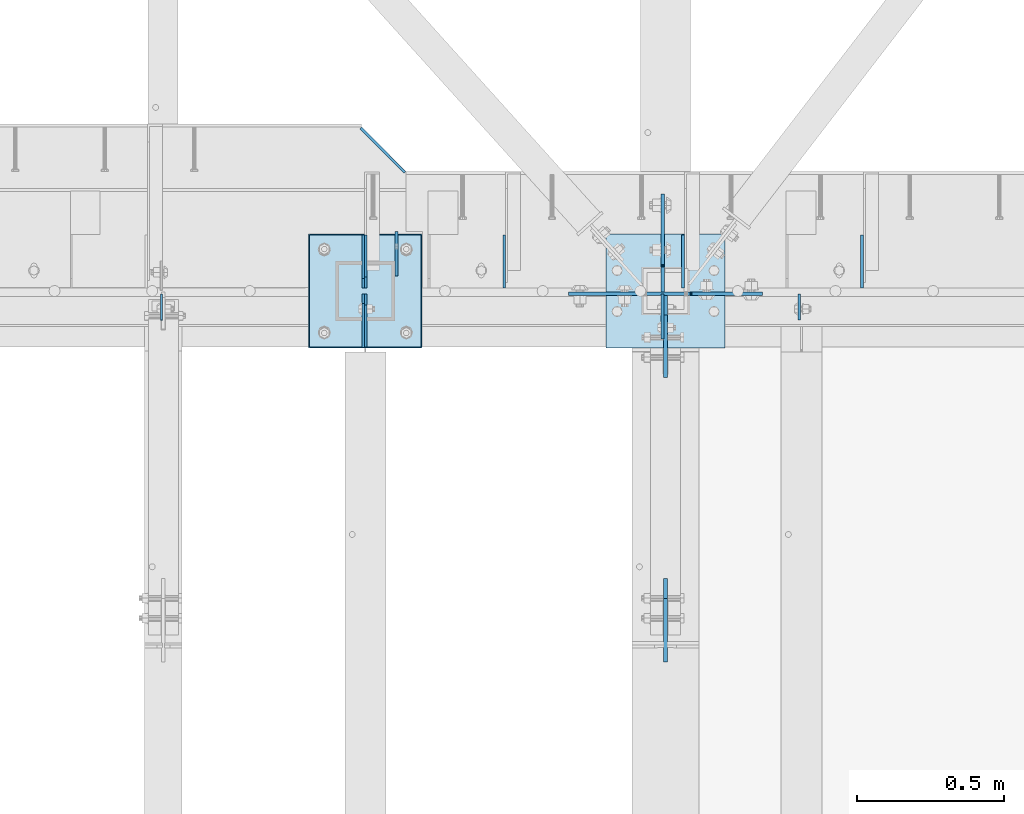
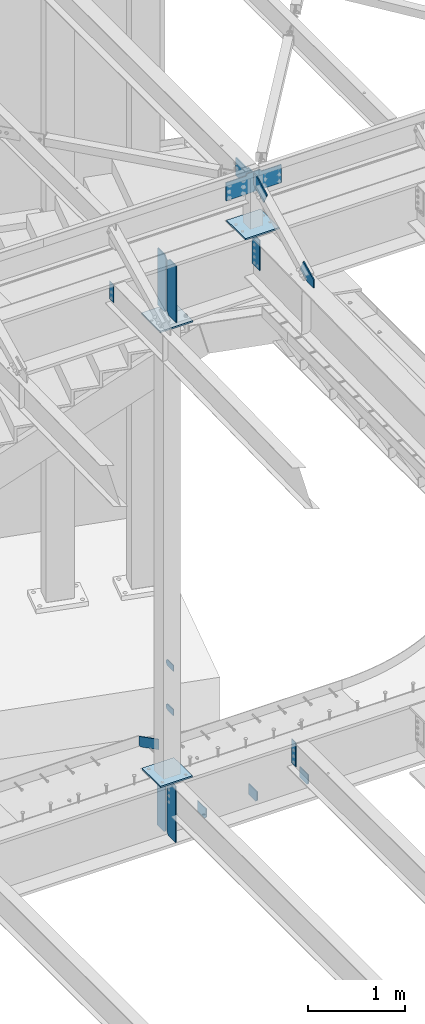
# One storey, part 1672 of 1763: 20 plates, 5 elements without a shape of their own.
"""IFC2X3 building model written with IfcOpenShell, lengths in millimetres."""

from ifc_helpers import new_model, si_unit, frame, origin_with_axes, place, context, subcontext, project, spatial, faceted_brep, material, type_object, element, aggregate, save


model = new_model("IFC2X3")

# Units and contexts
model_context = context("Model", 3, precision=1e-05, world=origin_with_axes())
body_context = subcontext(model_context, "Body", "Model", "MODEL_VIEW")
ifc_project = project(units=[si_unit("LENGTHUNIT", "METRE", prefix="MILLI"), si_unit("AREAUNIT", "SQUARE_METRE"), si_unit("VOLUMEUNIT", "CUBIC_METRE"), si_unit("MASSUNIT", "GRAM", prefix="KILO"), si_unit("TIMEUNIT", "SECOND"), si_unit("PLANEANGLEUNIT", "RADIAN"), si_unit("SOLIDANGLEUNIT", "STERADIAN"), si_unit("THERMODYNAMICTEMPERATUREUNIT", "DEGREE_CELSIUS"), si_unit("LUMINOUSINTENSITYUNIT", "LUMEN")], contexts=[model_context])

# Site, building, storey
site_placement = place(None, origin_with_axes())
site = spatial("IfcSite", under=ifc_project, at=site_placement, CompositionType="ELEMENT")
building_placement = place(site_placement, origin_with_axes())
building = spatial("IfcBuilding", under=site, at=building_placement, Name="Undefined", CompositionType="ELEMENT")
storey_placement = place(building_placement, origin_with_axes())
storey = spatial("IfcBuildingStorey", under=building, at=storey_placement, Name="Undefined", CompositionType="ELEMENT", Elevation=0.0)

# Assembly, plates
assembly_1_placement = place(storey_placement, origin_with_axes())
assembly_1 = element("IfcElementAssembly", 1, at=assembly_1_placement, inside=storey, Name="COLUMN", AssemblyPlace="NOTDEFINED", PredefinedType="RIGID_FRAME")
ifc_material_1 = material(Name="STEEL/A36")
plate_type_1 = type_object("IfcPlateType", PredefinedType="NOTDEFINED")
plate_1_placement = place(assembly_1_placement, frame((-26893.2747736984, 52171.6, 6489.69999847412), z_axis=(0.0, 0.0, -1.0), x_axis=(0.0, 1.0, 0.0)))
plate_1 = element("IfcPlate", 2, at=plate_1_placement, type_object=plate_type_1, material=ifc_material_1, Name="PLATE", context=body_context, shape_type="Brep", body=[
    faceted_brep([(0.0, -4.76249999999982, 0.0), (0.0, -4.76250000000073, 76.1999969482422), (0.0, 4.76250000000073, 76.1999969482422), (0.0, 4.76249999999982, 0.0), (114.299995422363, -4.76250000000073, 76.1999969482422), (114.299995422363, 4.76250000000073, 76.1999969482422), (126.073542436527, -4.76250000000073, 74.3352502937696), (126.073542436527, 4.76250000000073, 74.3352502937696), (136.694612637817, -4.76250000000073, 68.923544725345), (136.694612637817, 4.76250000000073, 68.923544725345), (145.123541673587, -4.76250000000073, 60.4946156895749), (145.123541673587, 4.76250000000073, 60.4946156895749), (150.535247242013, -4.76250000000073, 49.8735454882844), (150.535247242013, 4.76250000000073, 49.8735454882844), (152.399993896484, -4.76250000000073, 38.0999984741211), (152.399993896484, 4.76250000000073, 38.0999984741211), (150.535247242013, -4.76250000000073, 26.3264514599578), (150.535247242013, 4.76250000000073, 26.3264514599578), (145.123541673587, -4.76250000000073, 15.7053812586673), (145.123541673587, 4.76250000000073, 15.7053812586673), (136.694612637817, -4.76250000000073, 7.27645222289721), (136.694612637817, 4.76250000000073, 7.27645222289721), (126.073542436527, -4.76250000000073, 1.86474665447258), (126.073542436527, 4.76250000000073, 1.86474665447258), (114.299995422363, -4.76250000000073, 0.0), (114.299995422363, 4.76250000000073, 0.0)], [[[0, 1, 2, 3]], [[1, 4, 5, 2]], [[4, 6, 7, 5]], [[6, 8, 9, 7]], [[8, 10, 11, 9]], [[10, 12, 13, 11]], [[12, 14, 15, 13]], [[14, 16, 17, 15]], [[16, 18, 19, 17]], [[18, 20, 21, 19]], [[20, 22, 23, 21]], [[22, 24, 25, 23]], [[24, 0, 3, 25]], [[5, 7, 9, 11, 13, 15, 17, 19, 21, 23, 25, 3, 2]], [[24, 22, 20, 18, 16, 14, 12, 10, 8, 6, 4, 1, 0]]]),
])
plate_2_placement = place(assembly_1_placement, frame((-26893.2747736984, 52171.6, 5930.89999847412), z_axis=(0.0, 0.0, -1.0), x_axis=(0.0, 1.0, 0.0)))
plate_2 = element("IfcPlate", 3, at=plate_2_placement, type_object=plate_type_1, material=ifc_material_1, Name="PLATE", context=body_context, shape_type="Brep", body=[
    faceted_brep([(0.0, -4.76249999999982, 0.0), (0.0, -4.76250000000073, 76.1999969482422), (0.0, 4.76250000000073, 76.1999969482422), (0.0, 4.76249999999982, 0.0), (114.299995422363, -4.76250000000073, 76.1999969482422), (114.299995422363, 4.76250000000073, 76.1999969482422), (126.073542436527, -4.76250000000073, 74.3352502937696), (126.073542436527, 4.76250000000073, 74.3352502937696), (136.694612637817, -4.76250000000073, 68.923544725345), (136.694612637817, 4.76250000000073, 68.923544725345), (145.123541673587, -4.76250000000073, 60.4946156895749), (145.123541673587, 4.76250000000073, 60.4946156895749), (150.535247242013, -4.76250000000073, 49.8735454882844), (150.535247242013, 4.76250000000073, 49.8735454882844), (152.399993896484, -4.76250000000073, 38.0999984741211), (152.399993896484, 4.76250000000073, 38.0999984741211), (150.535247242013, -4.76250000000073, 26.3264514599578), (150.535247242013, 4.76250000000073, 26.3264514599578), (145.123541673587, -4.76250000000073, 15.7053812586673), (145.123541673587, 4.76250000000073, 15.7053812586673), (136.694612637817, -4.76250000000073, 7.27645222289721), (136.694612637817, 4.76250000000073, 7.27645222289721), (126.073542436527, -4.76250000000073, 1.86474665447258), (126.073542436527, 4.76250000000073, 1.86474665447258), (114.299995422363, -4.76250000000073, 0.0), (114.299995422363, 4.76250000000073, 0.0)], [[[0, 1, 2, 3]], [[1, 4, 5, 2]], [[4, 6, 7, 5]], [[6, 8, 9, 7]], [[8, 10, 11, 9]], [[10, 12, 13, 11]], [[12, 14, 15, 13]], [[14, 16, 17, 15]], [[16, 18, 19, 17]], [[18, 20, 21, 19]], [[20, 22, 23, 21]], [[22, 24, 25, 23]], [[24, 0, 3, 25]], [[5, 7, 9, 11, 13, 15, 17, 19, 21, 23, 25, 3, 2]], [[24, 22, 20, 18, 16, 14, 12, 10, 8, 6, 4, 1, 0]]]),
])

assembly_2_placement = place(storey_placement, origin_with_axes())
assembly_2 = element("IfcElementAssembly", 4, at=assembly_2_placement, inside=storey, Name="BEAM", AssemblyPlace="NOTDEFINED", PredefinedType="RIGID_FRAME")
plate_type_2 = type_object("IfcPlateType", PredefinedType="NOTDEFINED")
plate_3_placement = place(assembly_2_placement, frame((-25307.1995109278, 52311.3, 4575.175), z_axis=(0.0, 0.0, -1.0), x_axis=(0.0, -1.0, 0.0)))
plate_3 = element("IfcPlate", 5, at=plate_3_placement, type_object=plate_type_2, material=ifc_material_1, Name="PLATE", context=body_context, shape_type="Brep", body=[
    faceted_brep([(0.0, -4.76249999999982, 0.0), (0.0, -4.76250000000073, 136.524993896484), (0.0, 4.76250000000073, 136.524993896484), (0.0, 4.76249999999982, 0.0), (148.431243896484, -4.76250000000073, 136.524993896484), (148.431243896484, 4.76250000000073, 136.524993896484), (180.181243896484, -4.76250000000073, 104.774993896484), (180.181243896484, 4.76250000000073, 104.774993896484), (180.181243896484, -4.76250000000073, 0.0), (180.181243896484, 4.76250000000073, 0.0)], [[[0, 1, 2, 3]], [[1, 4, 5, 2]], [[4, 6, 7, 5]], [[6, 8, 9, 7]], [[8, 0, 3, 9]], [[5, 7, 9, 3, 2]], [[8, 6, 4, 1, 0]]]),
])
plate_4_placement = place(assembly_2_placement, frame((-25916.7995109278, 52311.3, 4575.175), z_axis=(0.0, 0.0, -1.0), x_axis=(0.0, -1.0, 0.0)))
plate_4 = element("IfcPlate", 6, at=plate_4_placement, type_object=plate_type_2, material=ifc_material_1, Name="PLATE", context=body_context, shape_type="Brep", body=[
    faceted_brep([(0.0, -4.76249999999982, 0.0), (0.0, -4.76250000000073, 136.524993896484), (0.0, 4.76250000000073, 136.524993896484), (0.0, 4.76249999999982, 0.0), (148.431243896484, -4.76250000000073, 136.524993896484), (148.431243896484, 4.76250000000073, 136.524993896484), (180.181243896484, -4.76250000000073, 104.774993896484), (180.181243896484, 4.76250000000073, 104.774993896484), (180.181243896484, -4.76250000000073, 0.0), (180.181243896484, 4.76250000000073, 0.0)], [[[0, 1, 2, 3]], [[1, 4, 5, 2]], [[4, 6, 7, 5]], [[6, 8, 9, 7]], [[8, 0, 3, 9]], [[5, 7, 9, 3, 2]], [[8, 6, 4, 1, 0]]]),
])
plate_5_placement = place(assembly_2_placement, frame((-26526.3995109278, 52311.3, 4575.175), z_axis=(0.0, 0.0, -1.0), x_axis=(0.0, -1.0, 0.0)))
plate_5 = element("IfcPlate", 7, at=plate_5_placement, type_object=plate_type_2, material=ifc_material_1, Name="PLATE", context=body_context, shape_type="Brep", body=[
    faceted_brep([(0.0, -4.76249999999982, 0.0), (0.0, -4.76250000000073, 136.524993896484), (0.0, 4.76250000000073, 136.524993896484), (0.0, 4.76249999999982, 0.0), (148.431243896484, -4.76250000000073, 136.524993896484), (148.431243896484, 4.76250000000073, 136.524993896484), (180.181243896484, -4.76250000000073, 104.774993896484), (180.181243896484, 4.76250000000073, 104.774993896484), (180.181243896484, -4.76250000000073, 0.0), (180.181243896484, 4.76250000000073, 0.0)], [[[0, 1, 2, 3]], [[1, 4, 5, 2]], [[4, 6, 7, 5]], [[6, 8, 9, 7]], [[8, 0, 3, 9]], [[5, 7, 9, 3, 2]], [[8, 6, 4, 1, 0]]]),
])
plate_type_3 = type_object("IfcPlateType", PredefinedType="NOTDEFINED")
plate_6_placement = place(assembly_2_placement, frame((-27006.7810236983, 52131.11875, 4438.65), z_axis=(0.0, 0.0, 1.0), x_axis=(0.0, 1.0, 0.0)))
plate_6 = element("IfcPlate", 8, at=plate_6_placement, type_object=plate_type_3, material=ifc_material_1, Name="PLATE", context=body_context, shape_type="Brep", body=[
    faceted_brep([(0.0, -4.76250000000073, 31.75), (0.0, -4.76250000000073, 685.799987792969), (0.0, 4.76250000000073, 685.799987792969), (0.0, 4.76250000000073, 31.75), (31.75, -4.76250000000073, 717.549987792969), (31.75, 4.76250000000073, 717.549987792969), (180.181243896484, -4.76250000000073, 717.549987792969), (180.181243896484, 4.76250000000073, 717.549987792969), (180.181243896484, -4.76250000000073, 0.0), (180.181243896484, 4.76250000000073, 0.0), (31.75, -4.76250000000073, 0.0), (31.75, 4.76250000000073, 0.0)], [[[0, 1, 2, 3]], [[1, 4, 5, 2]], [[4, 6, 7, 5]], [[6, 8, 9, 7]], [[8, 10, 11, 9]], [[10, 0, 3, 11]], [[5, 7, 9, 11, 3, 2]], [[10, 8, 6, 4, 1, 0]]]),
])

# Assembly, plate
assembly_3_placement = place(storey_placement, origin_with_axes())
assembly_3 = element("IfcElementAssembly", 9, at=assembly_3_placement, inside=storey, Name="BEAM", AssemblyPlace="NOTDEFINED", PredefinedType="RIGID_FRAME")
plate_type_4 = type_object("IfcPlateType", PredefinedType="NOTDEFINED")
plate_7_placement = place(assembly_3_placement, frame((-25986.9283674484, 52110.4812502128, 11658.8961266475), z_axis=(0.0, -1.0, 0.0), x_axis=(0.0, 0.0, -1.0)))
plate_7 = element("IfcPlate", 10, at=plate_7_placement, type_object=plate_type_4, material=ifc_material_1, Name="PLATE", context=body_context, shape_type="Brep", body=[
    faceted_brep([(0.0, -4.76249999999982, 0.0), (-3.05175672110636e-06, -4.7625000002663, 152.399993896484), (-3.05175490211695e-06, 4.76249999972788, 152.399993896484), (0.0, 4.76249999999982, 0.0), (381.0, -4.76250000000073, 152.399993896484), (381.0, 4.76250000000073, 152.399993896484), (381.0, -4.76250000000073, 0.0), (381.0, 4.76250000000073, 0.0)], [[[0, 1, 2, 3]], [[1, 4, 5, 2]], [[4, 6, 7, 5]], [[6, 0, 3, 7]], [[5, 7, 3, 2]], [[6, 4, 1, 0]]]),
])

# Plate
plate_type_5 = type_object("IfcPlateType", PredefinedType="NOTDEFINED")
plate_8_placement = place(assembly_2_placement, frame((-26864.5582259844, 52524.8725485468, 5203.82498576935), z_axis=(-0.706641744347541, 0.707571512347997, -7.68330992195843e-06), x_axis=(-3.2690000102163e-06, 7.59399998163732e-06, 0.999999999965822)))
plate_8 = element("IfcPlate", 11, at=plate_8_placement, type_object=plate_type_5, material=ifc_material_1, Name="PLATE", context=body_context, shape_type="Brep", body=[
    faceted_brep([(0.0, -4.76249999999982, 0.0), (0.00149703819442948, -4.76249999996435, 194.831439973022), (0.00149703819170099, 4.76250000004802, 194.83143997303), (0.0, 4.76249999999982, 0.0), (19.0516426503509, -4.762500000008, 213.88129629795), (19.0516426503473, 4.762500000008, 213.881296297957), (130.17663574206, -4.76250000027358, 213.880462646848), (130.176635742057, 4.76249999973879, 213.880462646841), (130.17500305171, -4.76250000028813, 3.63797880709171e-10), (130.175003051707, 4.7624999996915, 3.78349795937538e-10)], [[[0, 1, 2, 3]], [[1, 4, 5, 2]], [[4, 6, 7, 5]], [[6, 8, 9, 7]], [[8, 0, 3, 9]], [[5, 7, 9, 3, 2]], [[8, 6, 4, 1, 0]]]),
])

plate_type_6 = type_object("IfcPlateType", PredefinedType="NOTDEFINED")
plate_9_placement = place(assembly_3_placement, frame((-27693.8596174484, 52110.4812502128, 11658.8961266475), z_axis=(0.0, -1.0, 0.0), x_axis=(0.0, 0.0, -1.0)))
plate_9 = element("IfcPlate", 12, at=plate_9_placement, type_object=plate_type_6, material=ifc_material_1, Name="PLATE", context=body_context, shape_type="Brep", body=[
    faceted_brep([(1.81898940354586e-12, -3.17500000000291, 0.0), (0.0, -3.17499999999927, 88.9000015258789), (0.0, 3.17499999999927, 88.9000015258789), (-1.81898940354586e-12, 3.17499999997381, 0.0), (228.600006103516, -3.17499999999927, 88.9000015258789), (228.600006103516, 3.17499999999927, 88.9000015258789), (228.600006103516, -3.17500000001019, -7.27595761418343e-12), (228.600006103516, 3.17499999999563, -7.27595761418343e-12)], [[[0, 1, 2, 3]], [[1, 4, 5, 2]], [[4, 6, 7, 5]], [[6, 0, 3, 7]], [[5, 7, 3, 2]], [[6, 4, 1, 0]]]),
])

# Assembly, plate
assembly_4_placement = place(storey_placement, origin_with_axes())
assembly_4 = element("IfcElementAssembly", 13, at=assembly_4_placement, inside=storey, Name="BEAM", AssemblyPlace="NOTDEFINED", PredefinedType="RIGID_FRAME")
plate_type_7 = type_object("IfcPlateType", PredefinedType="NOTDEFINED")
plate_10_placement = place(assembly_4_placement, frame((-25976.6096174484, 50858.8044431339, 11721.3897393301), z_axis=(0.0, -0.0206852279954837, 0.999786037781472), x_axis=(0.0, 0.999786037781472, 0.0206852279954825)))
plate_10 = element("IfcPlate", 14, at=plate_10_placement, type_object=plate_type_7, material=ifc_material_1, Name="PLATE", context=body_context, shape_type="Brep", body=[
    faceted_brep([(0.0, -6.34999999999491, 1.45519152283669e-11), (1.45519152283669e-11, -6.34999999999854, 101.599998474047), (1.45519152283669e-11, 6.34999999999854, 101.599998474047), (0.0, 6.34999999999491, -2.91038304567337e-11), (218.951583862981, -6.34999999999854, 205.463943481234), (218.951583862981, 6.34999999999854, 205.463943481234), (284.27273559654, -6.34999999999854, 67.7725906370797), (284.27273559654, 6.34999999999854, 67.7725906370797), (141.413955688891, -6.34999999999854, -4.72937244921923e-11), (141.413955688891, 6.34999999999854, -4.72937244921923e-11)], [[[0, 1, 2, 3]], [[1, 4, 5, 2]], [[4, 6, 7, 5]], [[6, 8, 9, 7]], [[8, 0, 3, 9]], [[5, 7, 9, 3, 2]], [[8, 6, 4, 1, 0]]]),
])
aggregate(assembly_4, [plate_10])

assembly_5_placement = place(storey_placement, origin_with_axes())
assembly_5 = element("IfcElementAssembly", 15, at=assembly_5_placement, inside=storey, Name="COLUMN", AssemblyPlace="NOTDEFINED", PredefinedType="RIGID_FRAME")
plate_type_8 = type_object("IfcPlateType", PredefinedType="NOTDEFINED")
plate_11_placement = place(assembly_5_placement, frame((-25976.6096174484, 52104.9250000007, 12416.9092242053), z_axis=(0.0, -1.0, 0.0), x_axis=(0.0, 0.0, -1.0)))
plate_11 = element("IfcPlate", 16, at=plate_11_placement, type_object=plate_type_8, material=ifc_material_1, Name="PLATE", context=body_context, shape_type="Brep", body=[
    faceted_brep([(0.0, -6.34999999999491, 1.45519152283669e-11), (0.0, -6.34999999999854, 66.6750030517578), (0.0, 6.34999999999854, 66.6750030517578), (0.0, 6.34999999999491, -2.91038304567337e-11), (109.25341796875, -6.34999999999854, 278.831817626953), (109.25341796875, 6.34999999999854, 278.831817626953), (245.564117431641, -6.34999999999854, 210.676483154297), (245.564117431641, 6.34999999999854, 210.676483154297), (140.225875854492, -6.34999999999854, 0.0), (140.225875854492, 6.34999999999854, 0.0)], [[[0, 1, 2, 3]], [[1, 4, 5, 2]], [[4, 6, 7, 5]], [[6, 8, 9, 7]], [[8, 0, 3, 9]], [[5, 7, 9, 3, 2]], [[8, 6, 4, 1, 0]]]),
])

# Plate
plate_type_9 = type_object("IfcPlateType", PredefinedType="NOTDEFINED")
plate_12_placement = place(assembly_2_placement, frame((-25520.8812736984, 52110.48125, 5124.45), z_axis=(0.0, -1.0, 0.0), x_axis=(0.0, 0.0, -1.0)))
plate_12 = element("IfcPlate", 17, at=plate_12_placement, type_object=plate_type_9, material=ifc_material_1, Name="PLATE", context=body_context, shape_type="Brep", body=[
    faceted_brep([(0.0, -3.96900000000096, 0.0), (0.0, -3.96899999999732, 88.9000015258789), (0.0, 3.96899999999732, 88.9000015258789), (0.0, 3.96900000000096, 0.0), (304.799987792969, -3.96899999999732, 88.9000015258789), (304.799987792969, 3.96899999999732, 88.9000015258789), (304.799987792969, -3.96900000000096, -3.63797880709171e-11), (304.799987792969, 3.96900000000096, -3.63797880709171e-11)], [[[0, 1, 2, 3]], [[1, 4, 5, 2]], [[4, 6, 7, 5]], [[6, 0, 3, 7]], [[5, 7, 3, 2]], [[6, 4, 1, 0]]]),
])

plate_type_10 = type_object("IfcPlateType", PredefinedType="NOTDEFINED")
plate_13_placement = place(assembly_2_placement, frame((-27006.7820237632, 52110.48125, 4440.2375), z_axis=(0.0, 0.0, 1.0), x_axis=(0.0, -1.0, 0.0)))
plate_13 = element("IfcPlate", 18, at=plate_13_placement, type_object=plate_type_10, material=ifc_material_1, Name="PLATE", context=body_context, shape_type="Brep", body=[
    faceted_brep([(0.0, -3.96899999999732, 31.75), (0.0, -3.96900000000096, 684.212524414062), (0.0, 3.96900000000096, 684.212524414062), (0.0, 3.96899999999732, 31.75), (31.75, -3.96900000000096, 715.962524414062), (31.75, 3.96900000000096, 715.962524414062), (182.5625, -3.96900000000096, 715.962524414062), (182.5625, 3.96900000000096, 715.962524414062), (182.5625, -3.96899999999732, 0.0), (182.5625, 3.96899999999732, 0.0), (31.75, -3.96899999999732, 0.0), (31.75, 3.96899999999732, 0.0)], [[[0, 1, 2, 3]], [[1, 4, 5, 2]], [[4, 6, 7, 5]], [[6, 8, 9, 7]], [[8, 10, 11, 9]], [[10, 0, 3, 11]], [[5, 7, 9, 11, 3, 2]], [[10, 8, 6, 4, 1, 0]]]),
])

aggregate(assembly_2, [plate_3, plate_4, plate_5, plate_6, plate_8, plate_13, plate_12])

ifc_material_2 = material(Name="STEEL/A572-50")
plate_type_11 = type_object("IfcPlateType", PredefinedType="NOTDEFINED")
plate_14_placement = place(assembly_5_placement, frame((-25986.1346174461, 52209.700000001, 12433.3), z_axis=(0.0, 0.0, -1.0), x_axis=(0.0, -1.0, 0.0)))
plate_14 = element("IfcPlate", 19, at=plate_14_placement, type_object=plate_type_11, material=ifc_material_2, Name="PLATE", context=body_context, shape_type="Brep", body=[
    faceted_brep([(-241.300003051758, -6.34999999999854, 25.3999999999996), (-241.300003051758, 6.34999999999854, 25.3999999999996), (-6.34999980926659, 6.34999999999854, 25.3999999999996), (-6.34999980926659, -6.34999999999854, 25.3999999999996), (-1.48992029122019, 6.34999999999854, 24.4332700774121), (-1.48992029122019, -6.34999999999854, 24.4332700774121), (2.63025617693347, 6.34999999999854, 21.6802561769346), (2.63025617693347, -6.34999999999854, 21.6802561769346), (5.38327007740736, 6.34999999999854, 17.5600797087809), (5.38327007740736, -6.34999999999854, 17.5600797087809), (6.34999999999854, -6.34999999999854, 12.7000001907345), (6.34999999999854, 6.34999999999854, 12.7000001907345), (6.35000000000582, 6.35000000000036, 0.0), (6.34999990463257, -6.35000000000291, 0.0), (-241.300003051758, -6.34999999999854, 254.0), (92.0749969482422, -6.34999999999854, 254.0), (92.0749969482422, 6.34999999999854, 254.0), (-241.300003051758, 6.34999999999854, 254.0), (92.0749969482422, -6.34999999999854, 0.0), (92.0749969482422, 6.34999999999854, 0.0)], [[[0, 1, 2, 3]], [[3, 2, 4, 5]], [[5, 4, 6, 7]], [[7, 6, 8, 9]], [[10, 11, 12, 13]], [[9, 8, 11, 10]], [[14, 15, 16, 17]], [[15, 18, 19, 16]], [[19, 18, 13, 12]], [[6, 4, 2, 1, 17, 16, 19, 12, 11, 8]], [[14, 17, 1, 0]], [[18, 15, 14, 0, 3, 5, 7, 9, 10, 13]]]),
])

plate_15_placement = place(assembly_5_placement, frame((-26059.1596174479, 52111.2750003815, 12433.3), z_axis=(0.0, 0.0, -1.0), x_axis=(1.0, 0.0, 0.0)))
plate_15 = element("IfcPlate", 20, at=plate_15_placement, type_object=plate_type_11, material=ifc_material_2, Name="PLATE", context=body_context, shape_type="Brep", body=[
    faceted_brep([(-247.649993896484, -6.34999999999854, 25.3999996185303), (-247.649993896484, 6.34999999999854, 25.3999996185303), (-12.6999998092724, 6.34999999999854, 25.3999996185303), (-12.6999998092724, -6.34999999999854, 25.3999996185303), (-7.83992029122601, 6.34999999999854, 24.4332696959427), (-7.83992029122601, -6.34999999999854, 24.4332696959427), (-3.71974382307235, 6.34999999999854, 21.6802557954652), (-3.71974382307235, -6.34999999999854, 21.6802557954652), (-0.966729922594823, 6.34999999999854, 17.5600793273115), (-0.966729922594823, -6.34999999999854, 17.5600793273115), (-1.31614667686587e-12, -6.35, 12.6999998092651), (-1.06936913171421e-12, 6.34999923705982, 12.699999332428), (0.0, 6.34999999999491, -2.91038304567337e-11), (0.0, -6.34999999999491, 1.45519152283669e-11), (-247.649993896484, -6.34999999999854, 254.0), (412.75, -6.34999999999854, 254.0), (412.75, 6.34999999999854, 254.0), (-247.649993896484, 6.34999999999854, 254.0), (412.75, -6.34999999999854, 25.3999996185303), (412.75, 6.34999999999854, 25.3999996185303), (177.800005912781, -6.34999999999854, 25.3999996185303), (177.800005912781, 6.34999999999854, 25.3999996185303), (172.939926394734, -6.34999999999854, 24.4332696959427), (172.939926394734, 6.34999999999854, 24.4332696959427), (168.819749926581, -6.34999999999854, 21.6802557954652), (168.819749926581, 6.34999999999854, 21.6802557954652), (166.066736026103, -6.34999999999854, 17.5600793273115), (166.066736026103, 6.34999999999854, 17.5600793273115), (165.100006103516, -6.34999999999854, 12.6999998092651), (165.100006103516, 6.34999999999854, 12.6999998092651), (165.100006103516, -6.34999999999854, 0.0), (165.100006103516, 6.34999999999854, 0.0)], [[[0, 1, 2, 3]], [[3, 2, 4, 5]], [[5, 4, 6, 7]], [[7, 6, 8, 9]], [[10, 11, 12, 13]], [[9, 8, 11, 10]], [[14, 15, 16, 17]], [[15, 18, 19, 16]], [[18, 20, 21, 19]], [[20, 22, 23, 21]], [[22, 24, 25, 23]], [[24, 26, 27, 25]], [[26, 28, 29, 27]], [[28, 30, 31, 29]], [[31, 30, 13, 12]], [[6, 4, 2, 1, 17, 16, 19, 21, 23, 25, 27, 29, 31, 12, 11, 8]], [[14, 17, 1, 0]], [[30, 28, 26, 24, 22, 20, 18, 15, 14, 0, 3, 5, 7, 9, 10, 13]]]),
])

plate_type_12 = type_object("IfcPlateType", PredefinedType="NOTDEFINED")
plate_16_placement = place(assembly_5_placement, frame((-26179.8096204997, 52314.4750002138, 11757.0249917654), z_axis=(1.0, 0.0, 0.0), x_axis=(0.0, -1.0, 0.0)))
plate_16 = element("IfcPlate", 21, at=plate_16_placement, type_object=plate_type_12, material=ifc_material_1, Name="PLATE", context=body_context, shape_type="Brep", body=[
    faceted_brep([(0.0, -9.52500000000146, 0.0), (0.0, -9.52499999999964, 406.399993896484), (0.0, 9.52499999999964, 406.399993896484), (0.0, 9.52500000000146, 0.0), (387.350006103516, -9.52499999999964, 406.399993896484), (387.350006103516, 9.52499999999964, 406.399993896484), (387.350006103516, -9.52499999999964, 0.0), (387.350006103516, 9.52499999999964, 0.0)], [[[0, 1, 2, 3]], [[1, 4, 5, 2]], [[4, 6, 7, 5]], [[6, 0, 3, 7]], [[5, 7, 3, 2]], [[6, 4, 1, 0]]]),
])

aggregate(assembly_5, [plate_11, plate_14, plate_15, plate_16])

plate_17_placement = place(assembly_1_placement, frame((-26805.9622736983, 52314.475, 10944.2249917654), z_axis=(-1.0, 0.0, 0.0), x_axis=(0.0, -1.0, 0.0)))
plate_17 = element("IfcPlate", 22, at=plate_17_placement, type_object=plate_type_12, material=ifc_material_2, Name="PLATE", context=body_context, shape_type="Brep", body=[
    faceted_brep([(0.0, -9.52500000000146, 0.0), (1.54303415911272e-06, -9.52499999999964, 387.350006103516), (1.54303415911272e-06, 9.52499999999964, 387.350006103516), (0.0, 9.52500000000146, 0.0), (387.350006103516, -9.52499999999964, 387.350006103516), (387.350006103516, 9.52499999999964, 387.350006103516), (387.350006103516, -9.52499999999964, 0.0), (387.350006103516, 9.52499999999964, 0.0)], [[[0, 1, 2, 3]], [[1, 4, 5, 2]], [[4, 6, 7, 5]], [[6, 0, 3, 7]], [[5, 7, 3, 2]], [[6, 4, 1, 0]]]),
])

plate_type_13 = type_object("IfcPlateType", PredefinedType="NOTDEFINED")
plate_18_placement = place(assembly_3_placement, frame((-26999.6372736983, 51930.3000002128, 11707.8124917654), z_axis=(0.0, 0.0, -1.0), x_axis=(0.0, 1.0, 0.0)))
plate_18 = element("IfcPlate", 23, at=plate_18_placement, type_object=plate_type_13, material=ifc_material_2, Name="PLATE", context=body_context, shape_type="Brep", body=[
    faceted_brep([(0.0, -6.34999999999491, 1.45519152283669e-11), (0.0, -6.34999999999854, 714.375), (0.0, 6.34999999999854, 714.375), (0.0, 6.34999999999491, -2.91038304567337e-11), (142.081245422363, -6.34999999999854, 714.375), (142.081245422363, 6.34999999999854, 714.375), (180.181243896484, -6.34999999999854, 676.275001525879), (180.181243896484, 6.34999999999854, 676.275001525879), (180.181243896484, -6.34999999999854, 38.0999984741211), (180.181243896484, 6.34999999999854, 38.0999984741211), (142.081245422363, -6.34999999999854, 0.0), (142.081245422363, 6.34999999999854, 0.0)], [[[0, 1, 2, 3]], [[1, 4, 5, 2]], [[4, 6, 7, 5]], [[6, 8, 9, 7]], [[8, 10, 11, 9]], [[10, 0, 3, 11]], [[5, 7, 9, 11, 3, 2]], [[10, 8, 6, 4, 1, 0]]]),
])

plate_19_placement = place(assembly_3_placement, frame((-26999.6372736983, 52311.3000002128, 11707.8124917654), z_axis=(0.0, 0.0, -1.0), x_axis=(0.0, -1.0, 0.0)))
plate_19 = element("IfcPlate", 24, at=plate_19_placement, type_object=plate_type_13, material=ifc_material_2, Name="PLATE", context=body_context, shape_type="Brep", body=[
    faceted_brep([(0.0, -6.34999999999491, 1.45519152283669e-11), (0.0, -6.34999999999854, 714.375), (0.0, 6.34999999999854, 714.375), (0.0, 6.34999999999491, -2.91038304567337e-11), (142.081245422363, -6.34999999999854, 714.375), (142.081245422363, 6.34999999999854, 714.375), (180.181243896484, -6.34999999999854, 676.275001525879), (180.181243896484, 6.34999999999854, 676.275001525879), (180.181243896484, -6.34999999999854, 38.0999984741211), (180.181243896484, 6.34999999999854, 38.0999984741211), (142.081245422363, -6.34999999999854, 0.0), (142.081245422363, 6.34999999999854, 0.0)], [[[0, 1, 2, 3]], [[1, 4, 5, 2]], [[4, 6, 7, 5]], [[6, 8, 9, 7]], [[8, 10, 11, 9]], [[10, 0, 3, 11]], [[5, 7, 9, 11, 3, 2]], [[10, 8, 6, 4, 1, 0]]]),
])

aggregate(assembly_3, [plate_18, plate_19, plate_7, plate_9])

plate_type_14 = type_object("IfcPlateType", PredefinedType="NOTDEFINED")
plate_20_placement = place(assembly_1_placement, frame((-27190.1372736983, 52311.3, 5203.825), z_axis=(1.0, 0.0, 0.0), x_axis=(0.0, -1.0, 0.0)))
plate_20 = element("IfcPlate", 25, at=plate_20_placement, type_object=plate_type_14, material=ifc_material_2, Name="PLATE", context=body_context, shape_type="Brep", body=[
    faceted_brep([(0.0, -9.52500000000146, 0.0), (0.0, -9.52499999999964, 381.0), (0.0, 9.52499999999964, 381.0), (0.0, 9.52500000000146, 0.0), (381.0, -9.52499999999964, 381.0), (381.0, 9.52499999999964, 381.0), (381.0, -9.52499999999964, 0.0), (381.0, 9.52499999999964, 0.0)], [[[0, 1, 2, 3]], [[1, 4, 5, 2]], [[4, 6, 7, 5]], [[6, 0, 3, 7]], [[5, 7, 3, 2]], [[6, 4, 1, 0]]]),
])

aggregate(assembly_1, [plate_1, plate_2, plate_17, plate_20])

save(model, "model.ifc")
